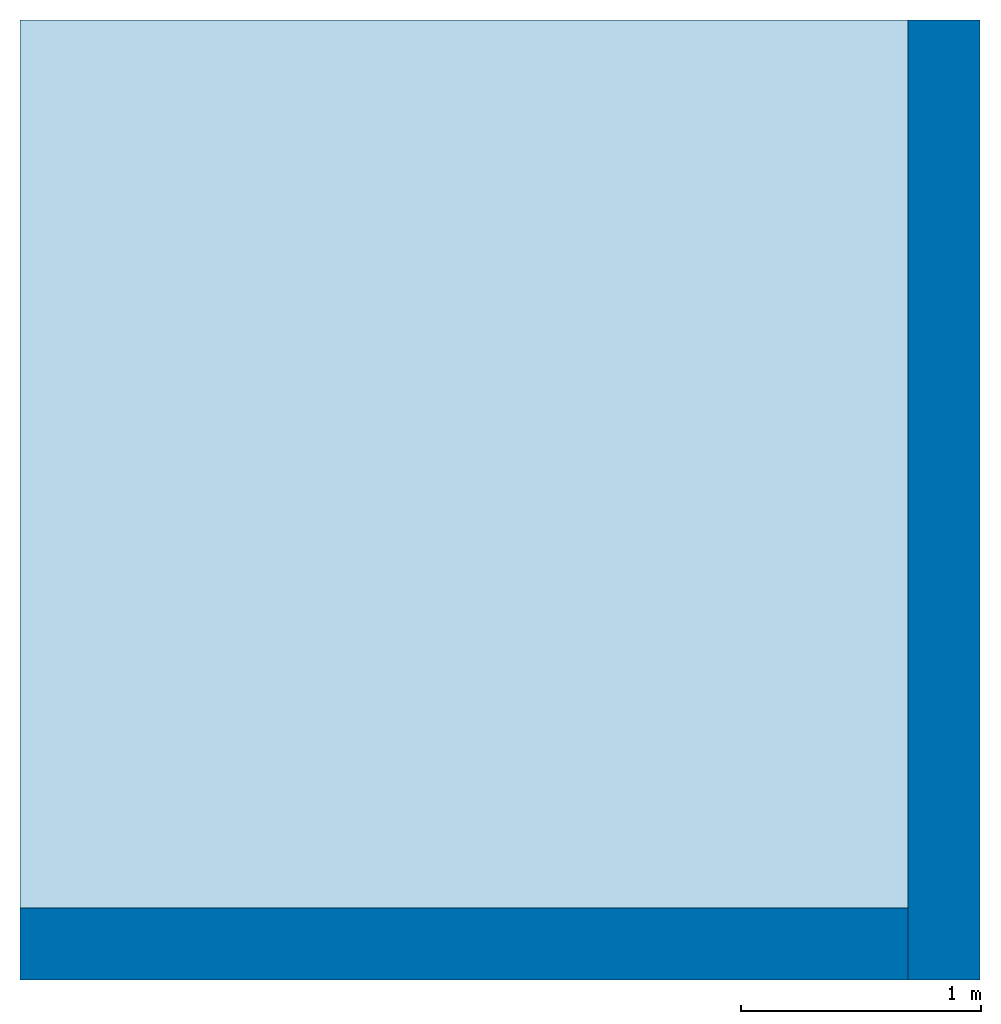
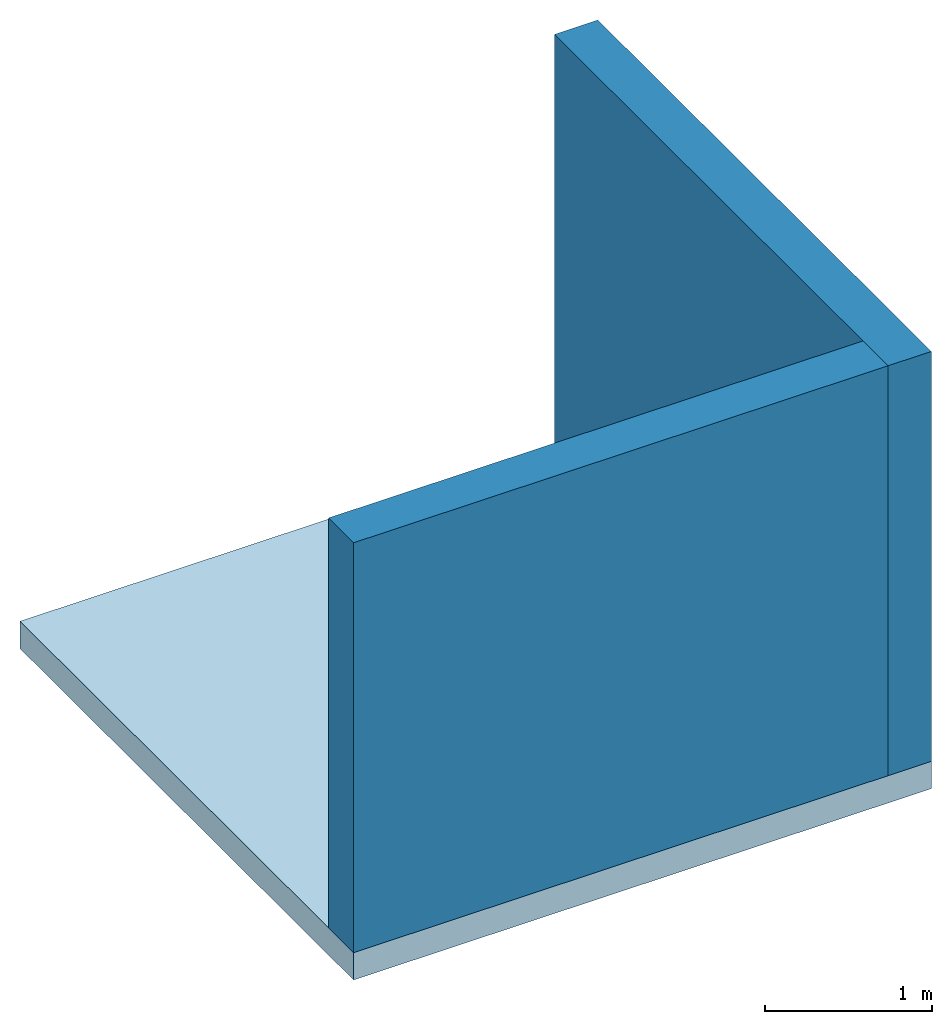
# One storey: 2 walls, 1 slab.
"""IFC4 building model written with IfcOpenShell, lengths in millimetres."""

from ifc_helpers import new_model, entity, si_unit, converted_unit, frame, origin_with_axes, origin_2d_with_axis, place, context, subcontext, project, spatial, line, indexed_curve, outline, extrude, material, layer, layer_set, layer_usage, type_object, element, save


model = new_model("IFC4")

# Units and contexts
model_context = context("Model", 3, precision=1e-05, world=origin_with_axes())
plan_context = context("Plan", 2, precision=1e-05, world=origin_2d_with_axis())
body_context = subcontext(model_context, "Body", "Model", "MODEL_VIEW")
ifc_project = project(units=[si_unit("VOLUMEUNIT", "CUBIC_METRE"), si_unit("LENGTHUNIT", "METRE", prefix="MILLI"), converted_unit("PLANEANGLEUNIT", "degree", entity("IfcReal", 0.0174532925199433), si_unit("PLANEANGLEUNIT", "RADIAN"), dimensions=[0, 0, 0, 0, 0, 0, 0]), si_unit("AREAUNIT", "SQUARE_METRE")], contexts=[model_context, plan_context])

# Site, building, storey
site_placement = place(None, origin_with_axes())
site = spatial("IfcSite", under=ifc_project, at=site_placement)
building_placement = place(site_placement, origin_with_axes())
building = spatial("IfcBuilding", under=site, at=building_placement, Name="Building")
storey_placement = place(building_placement, origin_with_axes())
storey = spatial("IfcBuildingStorey", under=building, at=storey_placement, Name="Storey")

# Slab
ifc_material = material()
ifc_layer_1 = layer(ifc_material, 200.0)
ifc_layer_set_1 = layer_set([ifc_layer_1])
ifc_layer_usage_1 = layer_usage(ifc_layer_set_1, "AXIS3", "POSITIVE", 0.0)
slab_type = type_object("IfcSlabType", Name="FLR150", PredefinedType="NOTDEFINED", material=ifc_layer_set_1)
slab_placement = place(storey_placement, frame((0.0, 0.0, -200.000002980232), z_axis=(0.0, 0.0, 1.0), x_axis=(1.0, 0.0, 0.0)))
element("IfcSlab", 1, at=slab_placement, inside=storey, type_object=slab_type, material=ifc_layer_usage_1, Name="Slab", context=body_context, shape_type="SweptSolid", body=[
    extrude(outline(indexed_curve([(0.0, 0.0), (4000.0, 0.0), (4000.0, 4000.0), (0.0, 4000.0)], segments=[line(4, 1), line(1, 2), line(2, 3), line(3, 4)], self_intersect=False)), None, (0.0, 0.0, 1.0), 200.0),
])

# Walls
ifc_layer_2 = layer(ifc_material, 300.0)
ifc_layer_set_2 = layer_set([ifc_layer_2])
ifc_layer_usage_2 = layer_usage(ifc_layer_set_2, "AXIS2", "POSITIVE", 0.0)
wall_type = type_object("IfcWallType", Name="WAL300", PredefinedType="NOTDEFINED", material=ifc_layer_set_2)
wall_1_placement = place(storey_placement, origin_with_axes())
element("IfcWall", 2, at=wall_1_placement, inside=storey, type_object=wall_type, material=ifc_layer_usage_2, Name="Wall", context=body_context, shape_type="SweptSolid", body=[
    extrude(outline(indexed_curve([(0.0, 0.0), (0.0, 300.0), (3700.00007216995, 300.0), (3700.00007216995, 0.0), (0.0, 0.0)], self_intersect=False)), origin_with_axes(), (0.0, 0.0, 1.0), 3000.0),
])
ifc_layer_usage_3 = layer_usage(ifc_layer_set_2, "AXIS2", "POSITIVE", 0.0)
wall_2_placement = place(storey_placement, frame((4000.0, 0.0, 0.0), z_axis=(0.0, 0.0, 1.0), x_axis=(3.13916473260163e-07, 0.999999999999951, 0.0)))
element("IfcWall", 3, at=wall_2_placement, inside=storey, type_object=wall_type, material=ifc_layer_usage_3, Name="Wall", context=body_context, shape_type="SweptSolid", body=[
    extrude(outline(indexed_curve([(0.0, 0.0), (0.0, 300.0), (4000.00000000045, 300.0), (4000.00000000045, 0.0), (0.0, 0.0)], self_intersect=False)), origin_with_axes(), (0.0, 0.0, 1.0), 3000.0),
])

save(model, "model.ifc")
